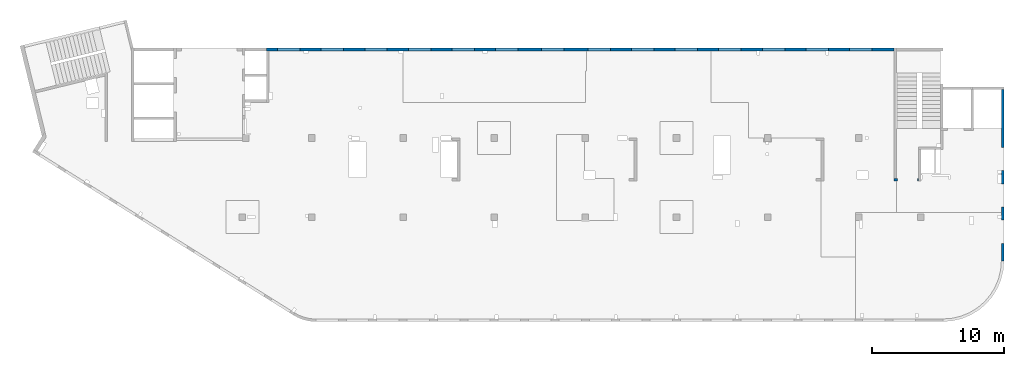
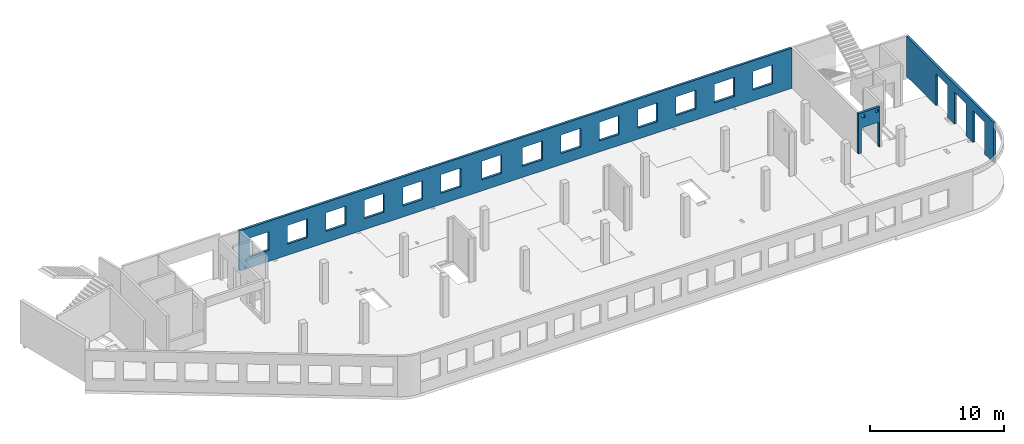
# One storey, part 6 of 6: 3 walls, 20 openings.
"""IFC4 building model written with IfcOpenShell, lengths in millimetres."""

from ifc_helpers import new_model, entity, si_unit, converted_unit, derived_unit, direction, frame, origin, place, context, subcontext, project, spatial, indexed_curve, outline, extrude, polygons, material, type_object, element, save


model = new_model("IFC4")

# Units and contexts
model_context = context("Model", 3, precision=0.01, world=origin(), true_north=direction((6.12303176911189e-17, 1.0)))
plan_context = context("Plan", 3, precision=0.01, world=origin(), true_north=direction((6.12303176911189e-17, 1.0)))
body_context = subcontext(model_context, "Body", "Model", "MODEL_VIEW")
ifc_project = project(units=[si_unit("LENGTHUNIT", "METRE", prefix="MILLI"), si_unit("AREAUNIT", "SQUARE_METRE"), si_unit("VOLUMEUNIT", "CUBIC_METRE"), converted_unit("PLANEANGLEUNIT", "DEGREE", entity("IfcRatioMeasure", 0.0174532925199433), si_unit("PLANEANGLEUNIT", "RADIAN"), dimensions=[0, 0, 0, 0, 0, 0, 0]), si_unit("MASSUNIT", "GRAM", prefix="KILO"), derived_unit("MASSDENSITYUNIT", [(si_unit("MASSUNIT", "GRAM", prefix="KILO"), 1), (si_unit("LENGTHUNIT", "METRE"), -3)]), derived_unit("MOMENTOFINERTIAUNIT", [(si_unit("LENGTHUNIT", "METRE"), 4)]), si_unit("TIMEUNIT", "SECOND"), si_unit("FREQUENCYUNIT", "HERTZ"), si_unit("THERMODYNAMICTEMPERATUREUNIT", "DEGREE_CELSIUS"), derived_unit("THERMALTRANSMITTANCEUNIT", [(si_unit("MASSUNIT", "GRAM", prefix="KILO"), 1), (si_unit("THERMODYNAMICTEMPERATUREUNIT", "KELVIN"), -1), (si_unit("TIMEUNIT", "SECOND"), -3)]), derived_unit("VOLUMETRICFLOWRATEUNIT", [(si_unit("LENGTHUNIT", "METRE"), 3), (si_unit("TIMEUNIT", "SECOND"), -1)]), derived_unit("MASSFLOWRATEUNIT", [(si_unit("MASSUNIT", "GRAM", prefix="KILO"), 1), (si_unit("TIMEUNIT", "SECOND"), -1)]), derived_unit("ROTATIONALFREQUENCYUNIT", [(si_unit("TIMEUNIT", "SECOND"), -1)]), si_unit("ELECTRICCURRENTUNIT", "AMPERE"), si_unit("ELECTRICVOLTAGEUNIT", "VOLT"), si_unit("POWERUNIT", "WATT"), si_unit("FORCEUNIT", "NEWTON", prefix="KILO"), si_unit("ILLUMINANCEUNIT", "LUX"), si_unit("LUMINOUSFLUXUNIT", "LUMEN"), si_unit("LUMINOUSINTENSITYUNIT", "CANDELA"), derived_unit("USERDEFINED", [(si_unit("MASSUNIT", "GRAM", prefix="KILO"), -1), (si_unit("LENGTHUNIT", "METRE"), -2), (si_unit("TIMEUNIT", "SECOND"), 3), (si_unit("LUMINOUSFLUXUNIT", "LUMEN"), 1)]), derived_unit("LINEARVELOCITYUNIT", [(si_unit("LENGTHUNIT", "METRE"), 1), (si_unit("TIMEUNIT", "SECOND"), -1)]), si_unit("PRESSUREUNIT", "PASCAL"), derived_unit("USERDEFINED", [(si_unit("LENGTHUNIT", "METRE"), -2), (si_unit("MASSUNIT", "GRAM", prefix="KILO"), 1), (si_unit("TIMEUNIT", "SECOND"), -2)]), derived_unit("LINEARFORCEUNIT", [(si_unit("MASSUNIT", "GRAM", prefix="KILO"), 1), (si_unit("LENGTHUNIT", "METRE"), 1), (si_unit("TIMEUNIT", "SECOND"), -2), (si_unit("LENGTHUNIT", "METRE"), -1)]), derived_unit("PLANARFORCEUNIT", [(si_unit("MASSUNIT", "GRAM", prefix="KILO"), 1), (si_unit("LENGTHUNIT", "METRE"), 1), (si_unit("TIMEUNIT", "SECOND"), -2), (si_unit("LENGTHUNIT", "METRE"), -2)])], contexts=[model_context, plan_context])

# Site, building, storey
site_placement = place(None, origin())
site = spatial("IfcSite", under=ifc_project, at=site_placement, CompositionType="ELEMENT")
building_placement = place(site_placement, origin())
building = spatial("IfcBuilding", under=site, at=building_placement, CompositionType="ELEMENT")
storey_placement = place(building_placement, frame((0.0, 0.0, 8100.0)))
storey = spatial("IfcBuildingStorey", under=building, at=storey_placement, Name="03", CompositionType="ELEMENT", Elevation=8100.0)

# Wall, openings
ifc_material = material()
wall_type = type_object("IfcWallType", Name=":ADSK_ 25_200", PredefinedType="STANDARD")
wall_1_placement = place(storey_placement, frame((73470.0, 17370.0, -150.0), z_axis=(0.0, 0.0, 1.0), x_axis=(0.0, -1.0, 0.0)))
wall_1 = element("IfcWall", 1, at=wall_1_placement, inside=storey, type_object=wall_type, material=ifc_material, Name=":ADSK_ 25_200", ObjectType=":ADSK_ 25_200", PredefinedType="NOTDEFINED", context=body_context, shape_type="Tessellation", body=[
    polygons([(12970.0, -99.9999999999918, 0.0), (12970.0, -99.9999999999918, 3200.0), (12970.0, -99.9999999999918, 3650.0), (9560.00000000002, -99.9999999999877, 3650.0), (9360.00000000002, -99.999999999988, 3650.0), (7085.00000000004, -99.999999999991, 3650.0), (6485.00000000003, -99.9999999999918, 3650.0), (6320.00000000002, -99.999999999992, 3650.0), (6120.00000000002, -99.9999999999923, 3650.0), (0.0, -99.9999999999831, 3650.0), (0.0, -99.9999999999831, 0.0), (4394.99999999951, -99.9999999999946, 0.0), (4394.99999999951, -100.000000000315, 2900.0), (6144.99999999951, -100.000000000313, 2900.0), (6144.99999999951, -99.9999999999923, 0.0), (6319.99895780055, -99.999999999992, 0.0), (6485.00000000002, -99.9999999999918, 0.0), (7084.99895780057, -99.999999999991, 0.0), (7144.99999999951, -99.9999999999909, 0.0), (7144.99999999951, -100.000000000311, 2900.0), (8894.99999999951, -100.000000000309, 2900.0), (8894.99999999951, -99.9999999999886, 0.0), (9895.00000000005, -99.9999999999959, 0.0), (9895.00000000005, -99.9999999999959, 2900.0), (11645.0, -99.9999999999936, 2900.0), (11645.0, -99.9999999999936, 0.0), (12970.0, 100.000000000006, 3650.0), (12970.0, 100.000000000006, 3200.0), (12970.0, 100.000000000006, 0.0), (11645.0, 100.000000000004, 0.0), (11645.0, 100.000000000316, 2900.0), (9895.00000000005, 100.000000000314, 2900.0), (9895.00000000004, 100.000000000002, 0.0), (8894.99999999951, 100.000000000001, 0.0), (8894.99999999951, 100.000000000001, 2900.0), (7144.99999999951, 99.9999999999983, 2900.0), (7144.99999999951, 99.9999999999983, 0.0), (6144.99999999951, 99.9999999999969, 0.0), (6144.99999999951, 99.9999999999969, 2900.0), (4394.99999999951, 99.9999999999946, 2900.0), (4394.99999999951, 99.9999999999946, 0.0), (0.0, 100.000000000006, 0.0), (0.0, 100.000000000006, 3650.0)], [[[1, 2, 3, 4, 5, 6, 7, 8, 9, 10, 11, 12, 13, 14, 15, 16, 17, 18, 19, 20, 21, 22, 23, 24, 25, 26]], [[27, 28, 29, 30, 31, 32, 33, 34, 35, 36, 37, 38, 39, 40, 41, 42, 43]], [[11, 42, 41, 12]], [[3, 2, 1, 29, 28, 27]], [[10, 9, 8, 7, 6, 5, 4, 3, 27, 43]], [[11, 10, 43, 42]], [[24, 32, 31, 25]], [[32, 24, 23, 33]], [[25, 31, 30, 26]], [[35, 21, 20, 36]], [[21, 35, 34, 22]], [[36, 20, 19, 37]], [[39, 14, 13, 40]], [[14, 39, 38, 15]], [[40, 13, 12, 41]], [[37, 19, 18, 17, 16, 15, 38]], [[33, 23, 22, 34]], [[29, 1, 26, 30]]], closed=True),
])
placement_1 = place(wall_1_placement, frame((17370.0, -73470.0, 150.0), z_axis=(0.0, 0.0, 1.0), x_axis=(0.0, 1.0, 0.0)))
element("IfcOpeningElement", 2, at=placement_1, cuts=wall_1, Name=":ADSK_ 25_200", PredefinedType="OPENING", context=body_context, shape_type="SweptSolid", body=[
    extrude(outline(indexed_curve([(-1449.99999999999, -874.999999999999), (1449.99999999999, -874.999999999999), (1449.99999999999, 875.0), (-1449.99999999999, 875.0), (-1449.99999999999, -874.999999999999)], self_intersect=False)), frame((73370.0, 6600.0, 1300.0), z_axis=(1.0, 0.0, 0.0), x_axis=(0.0, 0.0, -1.0)), (0.0, 0.0, 1.0), 200.000000000968),
])
element("IfcOpeningElement", 3, at=placement_1, cuts=wall_1, Name=":ADSK_ 25_200", PredefinedType="OPENING", context=body_context, shape_type="SweptSolid", body=[
    extrude(outline(indexed_curve([(-874.999999999999, -1449.99999999999), (874.999999999999, -1449.99999999999), (874.999999999999, 1450.0), (-874.999999999999, 1450.0), (-874.999999999999, -1449.99999999999)], self_intersect=False)), frame((73370.0, 9350.0, 1300.0), z_axis=(1.0, 0.0, 0.0), x_axis=(0.0, -1.0, 0.0)), (0.0, 0.0, 1.0), 200.000000000968),
])
element("IfcOpeningElement", 4, at=placement_1, cuts=wall_1, Name=":ADSK_ 25_200", PredefinedType="OPENING", context=body_context, shape_type="SweptSolid", body=[
    extrude(outline(indexed_curve([(-875.0, -1449.99999999999), (874.999999999998, -1449.99999999999), (874.999999999998, 1450.0), (-875.0, 1450.0), (-875.0, -1449.99999999999)], self_intersect=False)), frame((73370.0, 12100.0, 1300.0), z_axis=(1.0, 0.0, 0.0), x_axis=(0.0, -1.0, 0.0)), (0.0, 0.0, 1.0), 200.000000000968),
])

wall_2_placement = place(storey_placement, frame((67080.0, 10525.0, -150.0), z_axis=(0.0, 0.0, 1.0), x_axis=(-1.0, 0.0, 0.0)))
wall_2 = element("IfcWall", 5, at=wall_2_placement, inside=storey, type_object=wall_type, material=ifc_material, Name=":ADSK_ 25_200", ObjectType=":ADSK_ 25_200", PredefinedType="NOTDEFINED", context=body_context, shape_type="Tessellation", body=[
    polygons([(1849.99999999999, -100.000000000001, 3650.0), (1650.0, -100.000000000003, 3650.0), (-9.772240076716e-13, -100.000000000001, 3650.0), (-9.772240076716e-13, -100.000000000001, 0.0), (74.9999999999906, -100.000000000001, 0.0), (74.9999999999906, -100.000000000001, 2279.99999999805), (1575.0, -100.000000000001, 2279.99999999804), (1575.0, -100.000000000003, 0.0), (1650.0, -100.000000000003, 0.0), (1849.99999999999, -100.000000000001, 0.0), (125.000000000014, -100.000000000322, 3490.0), (375.000000000009, -100.000000000324, 3490.0), (375.000000000009, -100.000000000324, 3240.00000000001), (125.000000000014, -100.000000000322, 3240.00000000001), (1275.0, -100.000000000322, 3400.0), (1524.99999999999, -100.000000000322, 3400.0), (1524.99999999999, -100.000000000322, 3150.00000000001), (1275.0, -100.000000000322, 3150.00000000001), (-1.61109744921212e-12, 99.9999999999989, 3650.0), (1849.99999999999, 99.9999999999989, 3650.0), (1849.99999999999, 99.9999999999989, 0.0), (1575.0, 99.9999999999968, 0.0), (1575.0, 99.9999999999968, 2279.99999999804), (74.99999999999, 99.9999999999989, 2279.99999999805), (74.99999999999, 99.9999999999989, 0.0), (-1.61109744921212e-12, 99.9999999999989, 0.0), (375.000000000008, 99.9999999999968, 3490.0), (125.000000000013, 99.9999999999968, 3490.0), (125.000000000013, 99.9999999999968, 3240.00000000001), (375.000000000008, 99.9999999999968, 3240.00000000001), (1524.99999999999, 99.9999999999968, 3400.0), (1275.0, 99.9999999999989, 3400.0), (1275.0, 99.9999999999989, 3150.00000000001), (1524.99999999999, 99.9999999999968, 3150.00000000001)], [[[1, 2, 3, 4, 5, 6, 7, 8, 9, 10], [11, 12, 13, 14], [15, 16, 17, 18]], [[19, 20, 21, 22, 23, 24, 25, 26], [27, 28, 29, 30], [31, 32, 33, 34]], [[4, 26, 25, 5]], [[3, 2, 1, 20, 19]], [[4, 3, 19, 26]], [[1, 10, 21, 20]], [[12, 11, 28, 27]], [[12, 27, 30, 13]], [[13, 30, 29, 14]], [[28, 11, 14, 29]], [[16, 15, 32, 31]], [[16, 31, 34, 17]], [[17, 34, 33, 18]], [[32, 15, 18, 33]], [[6, 24, 23, 7]], [[7, 23, 22, 8]], [[24, 6, 5, 25]], [[21, 10, 9, 8, 22]]], closed=True),
])
placement_2 = place(wall_2_placement, frame((67080.0, 10525.0, 150.0), z_axis=(0.0, 0.0, 1.0), x_axis=(-1.0, 0.0, 0.0)))
element("IfcOpeningElement", 6, at=placement_2, cuts=wall_2, Name=":ADSK_ 25_200", PredefinedType="OPENING", context=body_context, shape_type="SweptSolid", body=[
    extrude(outline(indexed_curve([(-750.000000000003, -1139.99999999902), (749.999999999994, -1139.99999999902), (749.999999999994, 1139.99999999902), (-750.000000000003, 1139.99999999902), (-750.000000000003, -1139.99999999902)], self_intersect=False)), frame((66255.0, 10725.0, 990.0), z_axis=(0.0, -1.0, 0.0), x_axis=(-1.0, 0.0, 0.0)), (0.0, 0.0, 1.0), 400.000000001943),
])
element("IfcOpeningElement", 7, at=placement_2, cuts=wall_2, Name=":ADSK_ 25_200", PredefinedType="OPENING", context=body_context, shape_type="SweptSolid", body=[
    extrude(outline(indexed_curve([(-125.000000000006, -124.999999999993), (124.999999999998, -124.999999999993), (124.999999999998, 124.999999999993), (-125.000000000006, 124.999999999993), (-125.000000000006, -124.999999999993)], self_intersect=False)), frame((65680.0, 10625.0, 3125.0), z_axis=(0.0, -1.0, 0.0), x_axis=(-1.0, 0.0, 0.0)), (0.0, 0.0, 1.0), 200.000000000962),
])
element("IfcOpeningElement", 8, at=placement_2, cuts=wall_2, Name=":ADSK_ 25_200", PredefinedType="OPENING", context=body_context, shape_type="SweptSolid", body=[
    extrude(outline(indexed_curve([(-125.000000000006, -124.999999999993), (124.999999999998, -124.999999999993), (124.999999999998, 124.999999999993), (-125.000000000006, 124.999999999993), (-125.000000000006, -124.999999999993)], self_intersect=False)), frame((66830.0, 10625.0, 3215.0), z_axis=(0.0, -1.0, 0.0), x_axis=(-1.0, 0.0, 0.0)), (0.0, 0.0, 1.0), 200.000000000962),
])

wall_3_placement = place(storey_placement, frame((65230.0, 20400.0, -150.0), z_axis=(0.0, 0.0, 1.0), x_axis=(-1.0, 0.0, 0.0)))
wall_3 = element("IfcWall", 9, at=wall_3_placement, inside=storey, type_object=wall_type, material=ifc_material, Name=":ADSK_ 25_200", ObjectType=":ADSK_ 25_200", PredefinedType="NOTDEFINED", context=body_context, shape_type="Tessellation", body=[
    polygons([(8.66293703438714e-12, -99.9999999999989, 0.0), (47505.0, -99.9999999999989, 0.0), (47505.0, -99.9999999999989, 3650.0), (8.66293703438714e-12, -99.9999999999989, 3650.0), (28460.0, -100.000000000319, 2700.0), (30160.0, -100.000000000319, 2700.0), (30160.0, -100.000000000319, 1000.00000000001), (28460.0, -100.000000000319, 1000.00000000001), (1660.00000000009, -100.000000000319, 2700.0), (3360.00000000009, -100.000000000319, 2700.0), (3360.00000000009, -100.000000000319, 1000.00000000001), (1660.00000000009, -100.000000000319, 1000.00000000001), (4960.00000000009, -100.000000000319, 2700.0), (6660.00000000009, -100.000000000319, 2700.0), (6660.00000000009, -100.000000000319, 1000.00000000001), (4960.00000000009, -100.000000000319, 1000.00000000001), (8260.00000000008, -100.000000000319, 2700.0), (9960.00000000008, -100.000000000319, 2700.0), (9960.00000000008, -100.000000000319, 1000.00000000001), (8260.00000000008, -100.000000000319, 1000.00000000001), (11560.0000000001, -100.000000000319, 2700.0), (13260.0000000001, -100.000000000319, 2700.0), (13260.0000000001, -100.000000000319, 1000.00000000001), (11560.0000000001, -100.000000000319, 1000.00000000001), (14860.0000000001, -100.000000000319, 2700.0), (16560.0000000001, -100.000000000319, 2700.0), (16560.0000000001, -100.000000000319, 1000.00000000001), (14860.0000000001, -100.000000000319, 1000.00000000001), (18160.0000000001, -100.000000000319, 2700.0), (19860.0000000001, -100.000000000319, 2700.0), (19860.0000000001, -100.000000000319, 1000.00000000001), (18160.0000000001, -100.000000000319, 1000.00000000001), (21460.0000000001, -100.000000000319, 2700.0), (23160.0000000001, -100.000000000319, 2700.0), (23160.0000000001, -100.000000000319, 1000.00000000001), (21460.0000000001, -100.000000000319, 1000.00000000001), (24960.0000000001, -100.000000000319, 2700.0), (26660.0000000001, -100.000000000319, 2700.0), (26660.0000000001, -100.000000000319, 1000.00000000001), (24960.0000000001, -100.000000000319, 1000.00000000001), (31760.0000000001, -100.000000000319, 2700.0), (33460.0000000001, -100.000000000319, 2700.0), (33460.0000000001, -100.000000000319, 1000.00000000001), (31760.0000000001, -100.000000000319, 1000.00000000001), (35060.0000000001, -100.000000000319, 2700.0), (36760.0000000001, -100.000000000319, 2700.0), (36760.0000000001, -100.000000000319, 1000.00000000001), (35060.0000000001, -100.000000000319, 1000.00000000001), (38360.0000000001, -100.000000000319, 2700.0), (40060.0000000001, -100.000000000319, 2700.0), (40060.0000000001, -100.000000000319, 1000.00000000001), (38360.0000000001, -100.000000000319, 1000.00000000001), (41660.0, -100.000000000319, 2700.0), (43360.0, -100.000000000319, 2700.0), (43360.0, -100.000000000319, 1000.00000000001), (41660.0, -100.000000000319, 1000.00000000001), (44960.0, -100.000000000319, 2700.0), (46660.0, -100.000000000319, 2700.0), (46660.0, -100.000000000319, 1000.00000000001), (44960.0, -100.000000000319, 1000.00000000001), (8.66293703438714e-12, 99.9999999999989, 0.0), (8.66293703438714e-12, 99.9999999999989, 3650.0), (47305.0, 99.9999999999989, 3650.0), (47505.0, 99.9999999999989, 3650.0), (47505.0, 99.9999999999989, 0.0), (47305.0, 99.9999999999989, 0.0), (44660.0000000001, 99.9999999999989, 0.0), (44360.0000000001, 99.9999999999989, 0.0), (37460.0000000001, 99.9999999999989, 0.0), (37160.0000000001, 99.9999999999989, 0.0), (10360.0000000001, 99.9999999999989, 0.0), (10160.0000000001, 99.9999999999989, 0.0), (5150.00000000013, 99.9999999999989, 0.0), (4950.0000000001, 99.9999999999989, 0.0), (30160.0, 99.9999999999989, 2700.0), (28460.0, 99.9999999999989, 2700.0), (28460.0, 99.9999999999989, 1000.00000000001), (30160.0, 99.9999999999989, 1000.00000000001), (3360.00000000009, 99.9999999999989, 2700.0), (1660.00000000009, 99.9999999999989, 2700.0), (1660.00000000009, 99.9999999999989, 1000.00000000001), (3360.00000000009, 99.9999999999989, 1000.00000000001), (6660.00000000009, 99.9999999999989, 2700.0), (4960.00000000009, 99.9999999999989, 2700.0), (4960.00000000009, 99.9999999999989, 1000.00000000001), (6660.00000000009, 99.9999999999989, 1000.00000000001), (9960.00000000008, 99.9999999999989, 2700.0), (8260.00000000008, 99.9999999999989, 2700.0), (8260.00000000008, 99.9999999999989, 1000.00000000001), (9960.00000000008, 99.9999999999989, 1000.00000000001), (13260.0000000001, 99.9999999999989, 2700.0), (11560.0000000001, 99.9999999999989, 2700.0), (11560.0000000001, 99.9999999999989, 1000.00000000001), (13260.0000000001, 99.9999999999989, 1000.00000000001), (16560.0000000001, 99.9999999999989, 2700.0), (14860.0000000001, 99.9999999999989, 2700.0), (14860.0000000001, 99.9999999999989, 1000.00000000001), (16560.0000000001, 99.9999999999989, 1000.00000000001), (19860.0000000001, 99.9999999999989, 2700.0), (18160.0000000001, 99.9999999999989, 2700.0), (18160.0000000001, 99.9999999999989, 1000.00000000001), (19860.0000000001, 99.9999999999989, 1000.00000000001), (23160.0000000001, 99.9999999999989, 2700.0), (21460.0000000001, 99.9999999999989, 2700.0), (21460.0000000001, 99.9999999999989, 1000.00000000001), (23160.0000000001, 99.9999999999989, 1000.00000000001), (26660.0000000001, 99.9999999999989, 2700.0), (24960.0000000001, 99.9999999999989, 2700.0), (24960.0000000001, 99.9999999999989, 1000.00000000001), (26660.0000000001, 99.9999999999989, 1000.00000000001), (33460.0000000001, 99.9999999999989, 2700.0), (31760.0000000001, 99.9999999999989, 2700.0), (31760.0000000001, 99.9999999999989, 1000.00000000001), (33460.0000000001, 99.9999999999989, 1000.00000000001), (36760.0000000001, 99.9999999999989, 2700.0), (35060.0000000001, 99.9999999999989, 2700.0), (35060.0000000001, 99.9999999999989, 1000.00000000001), (36760.0000000001, 99.9999999999989, 1000.00000000001), (40060.0000000001, 99.9999999999989, 2700.0), (38360.0000000001, 99.9999999999989, 2700.0), (38360.0000000001, 99.9999999999989, 1000.00000000001), (40060.0000000001, 99.9999999999989, 1000.00000000001), (43360.0, 99.9999999999989, 2700.0), (41660.0, 99.9999999999989, 2700.0), (41660.0, 99.9999999999989, 1000.00000000001), (43360.0, 99.9999999999989, 1000.00000000001), (46660.0, 99.9999999999989, 2700.0), (44960.0, 99.9999999999989, 2700.0), (44960.0, 99.9999999999989, 1000.00000000001), (46660.0, 99.9999999999989, 1000.00000000001)], [[[1, 2, 3, 4], [5, 6, 7, 8], [9, 10, 11, 12], [13, 14, 15, 16], [17, 18, 19, 20], [21, 22, 23, 24], [25, 26, 27, 28], [29, 30, 31, 32], [33, 34, 35, 36], [37, 38, 39, 40], [41, 42, 43, 44], [45, 46, 47, 48], [49, 50, 51, 52], [53, 54, 55, 56], [57, 58, 59, 60]], [[61, 62, 63, 64, 65, 66, 67, 68, 69, 70, 71, 72, 73, 74], [75, 76, 77, 78], [79, 80, 81, 82], [83, 84, 85, 86], [87, 88, 89, 90], [91, 92, 93, 94], [95, 96, 97, 98], [99, 100, 101, 102], [103, 104, 105, 106], [107, 108, 109, 110], [111, 112, 113, 114], [115, 116, 117, 118], [119, 120, 121, 122], [123, 124, 125, 126], [127, 128, 129, 130]], [[2, 1, 61, 74, 73, 72, 71, 70, 69, 68, 67, 66, 65]], [[4, 3, 64, 63, 62]], [[1, 4, 62, 61]], [[3, 2, 65, 64]], [[6, 5, 76, 75]], [[6, 75, 78, 7]], [[7, 78, 77, 8]], [[76, 5, 8, 77]], [[10, 9, 80, 79]], [[10, 79, 82, 11]], [[11, 82, 81, 12]], [[80, 9, 12, 81]], [[14, 13, 84, 83]], [[14, 83, 86, 15]], [[15, 86, 85, 16]], [[84, 13, 16, 85]], [[18, 17, 88, 87]], [[18, 87, 90, 19]], [[19, 90, 89, 20]], [[88, 17, 20, 89]], [[22, 21, 92, 91]], [[22, 91, 94, 23]], [[23, 94, 93, 24]], [[92, 21, 24, 93]], [[26, 25, 96, 95]], [[26, 95, 98, 27]], [[27, 98, 97, 28]], [[96, 25, 28, 97]], [[30, 29, 100, 99]], [[30, 99, 102, 31]], [[31, 102, 101, 32]], [[100, 29, 32, 101]], [[34, 33, 104, 103]], [[34, 103, 106, 35]], [[35, 106, 105, 36]], [[104, 33, 36, 105]], [[38, 37, 108, 107]], [[38, 107, 110, 39]], [[39, 110, 109, 40]], [[108, 37, 40, 109]], [[42, 41, 112, 111]], [[42, 111, 114, 43]], [[43, 114, 113, 44]], [[112, 41, 44, 113]], [[46, 45, 116, 115]], [[46, 115, 118, 47]], [[47, 118, 117, 48]], [[116, 45, 48, 117]], [[50, 49, 120, 119]], [[50, 119, 122, 51]], [[51, 122, 121, 52]], [[120, 49, 52, 121]], [[54, 53, 124, 123]], [[54, 123, 126, 55]], [[55, 126, 125, 56]], [[124, 53, 56, 125]], [[58, 57, 128, 127]], [[58, 127, 130, 59]], [[59, 130, 129, 60]], [[128, 57, 60, 129]]], closed=True),
])
placement_3 = place(wall_3_placement, frame((65230.0, 20400.0, 150.0), z_axis=(0.0, 0.0, 1.0), x_axis=(-1.0, 0.0, 0.0)))
element("IfcOpeningElement", 10, at=placement_3, cuts=wall_3, Name=":ADSK_ 25_200", PredefinedType="OPENING", context=body_context, shape_type="SweptSolid", body=[
    extrude(outline(indexed_curve([(-850.000000000002, -849.999999999995), (850.0, -849.999999999995), (850.0, 849.999999999993), (-850.000000000002, 849.999999999993), (-850.000000000002, -849.999999999995)], self_intersect=False)), frame((19420.0, 20500.0, 1700.0), z_axis=(0.0, -1.0, 0.0), x_axis=(-1.0, 0.0, 0.0)), (0.0, 0.0, 1.0), 200.000000000959),
])
element("IfcOpeningElement", 11, at=placement_3, cuts=wall_3, Name=":ADSK_ 25_200", PredefinedType="OPENING", context=body_context, shape_type="SweptSolid", body=[
    extrude(outline(indexed_curve([(-850.000000000002, -849.999999999995), (849.999999999997, -849.999999999995), (849.999999999997, 849.999999999993), (-850.000000000002, 849.999999999993), (-850.000000000002, -849.999999999995)], self_intersect=False)), frame((22720.0, 20500.0, 1700.0), z_axis=(0.0, -1.0, 0.0), x_axis=(-1.0, 0.0, 0.0)), (0.0, 0.0, 1.0), 200.000000000959),
])
element("IfcOpeningElement", 12, at=placement_3, cuts=wall_3, Name=":ADSK_ 25_200", PredefinedType="OPENING", context=body_context, shape_type="SweptSolid", body=[
    extrude(outline(indexed_curve([(-850.000000000002, -849.999999999995), (849.999999999997, -849.999999999995), (849.999999999997, 849.999999999993), (-850.000000000002, 849.999999999993), (-850.000000000002, -849.999999999995)], self_intersect=False)), frame((26020.0, 20500.0, 1700.0), z_axis=(0.0, -1.0, 0.0), x_axis=(-1.0, 0.0, 0.0)), (0.0, 0.0, 1.0), 200.000000000959),
])
element("IfcOpeningElement", 13, at=placement_3, cuts=wall_3, Name=":ADSK_ 25_200", PredefinedType="OPENING", context=body_context, shape_type="SweptSolid", body=[
    extrude(outline(indexed_curve([(-850.000000000002, -849.999999999995), (849.999999999997, -849.999999999995), (849.999999999997, 849.999999999993), (-850.000000000002, 849.999999999993), (-850.000000000002, -849.999999999995)], self_intersect=False)), frame((29320.0, 20500.0, 1700.0), z_axis=(0.0, -1.0, 0.0), x_axis=(-1.0, 0.0, 0.0)), (0.0, 0.0, 1.0), 200.000000000959),
])
element("IfcOpeningElement", 14, at=placement_3, cuts=wall_3, Name=":ADSK_ 25_200", PredefinedType="OPENING", context=body_context, shape_type="SweptSolid", body=[
    extrude(outline(indexed_curve([(-849.999999999997, -849.999999999995), (850.000000000002, -849.999999999995), (850.000000000002, 849.999999999993), (-849.999999999997, 849.999999999993), (-849.999999999997, -849.999999999995)], self_intersect=False)), frame((32620.0, 20500.0, 1700.0), z_axis=(0.0, -1.0, 0.0), x_axis=(-1.0, 0.0, 0.0)), (0.0, 0.0, 1.0), 200.000000000959),
])
element("IfcOpeningElement", 15, at=placement_3, cuts=wall_3, Name=":ADSK_ 25_200", PredefinedType="OPENING", context=body_context, shape_type="SweptSolid", body=[
    extrude(outline(indexed_curve([(-849.999999999997, -849.999999999995), (850.000000000006, -849.999999999995), (850.000000000006, 849.999999999993), (-849.999999999997, 849.999999999993), (-849.999999999997, -849.999999999995)], self_intersect=False)), frame((39420.0, 20500.0, 1700.0), z_axis=(0.0, -1.0, 0.0), x_axis=(-1.0, 0.0, 0.0)), (0.0, 0.0, 1.0), 200.000000000959),
])
element("IfcOpeningElement", 16, at=placement_3, cuts=wall_3, Name=":ADSK_ 25_200", PredefinedType="OPENING", context=body_context, shape_type="SweptSolid", body=[
    extrude(outline(indexed_curve([(-850.000000000006, -849.999999999995), (849.999999999997, -849.999999999995), (849.999999999997, 849.999999999993), (-850.000000000006, 849.999999999993), (-850.000000000006, -849.999999999995)], self_intersect=False)), frame((42920.0, 20500.0, 1700.0), z_axis=(0.0, -1.0, 0.0), x_axis=(-1.0, 0.0, 0.0)), (0.0, 0.0, 1.0), 200.000000000959),
])
element("IfcOpeningElement", 17, at=placement_3, cuts=wall_3, Name=":ADSK_ 25_200", PredefinedType="OPENING", context=body_context, shape_type="SweptSolid", body=[
    extrude(outline(indexed_curve([(-849.999999999997, -849.999999999995), (850.000000000006, -849.999999999995), (850.000000000006, 849.999999999993), (-849.999999999997, 849.999999999993), (-849.999999999997, -849.999999999995)], self_intersect=False)), frame((46220.0, 20500.0, 1700.0), z_axis=(0.0, -1.0, 0.0), x_axis=(-1.0, 0.0, 0.0)), (0.0, 0.0, 1.0), 200.000000000959),
])
element("IfcOpeningElement", 18, at=placement_3, cuts=wall_3, Name=":ADSK_ 25_200", PredefinedType="OPENING", context=body_context, shape_type="SweptSolid", body=[
    extrude(outline(indexed_curve([(-849.999999999997, -849.999999999995), (850.000000000006, -849.999999999995), (850.000000000006, 849.999999999993), (-849.999999999997, 849.999999999993), (-849.999999999997, -849.999999999995)], self_intersect=False)), frame((49520.0, 20500.0, 1700.0), z_axis=(0.0, -1.0, 0.0), x_axis=(-1.0, 0.0, 0.0)), (0.0, 0.0, 1.0), 200.000000000959),
])
element("IfcOpeningElement", 19, at=placement_3, cuts=wall_3, Name=":ADSK_ 25_200", PredefinedType="OPENING", context=body_context, shape_type="SweptSolid", body=[
    extrude(outline(indexed_curve([(-849.999999999997, -849.999999999995), (850.000000000006, -849.999999999995), (850.000000000006, 849.999999999993), (-849.999999999997, 849.999999999993), (-849.999999999997, -849.999999999995)], self_intersect=False)), frame((52820.0, 20500.0, 1700.0), z_axis=(0.0, -1.0, 0.0), x_axis=(-1.0, 0.0, 0.0)), (0.0, 0.0, 1.0), 200.000000000959),
])
element("IfcOpeningElement", 20, at=placement_3, cuts=wall_3, Name=":ADSK_ 25_200", PredefinedType="OPENING", context=body_context, shape_type="SweptSolid", body=[
    extrude(outline(indexed_curve([(-849.999999999997, -849.999999999995), (850.000000000006, -849.999999999995), (850.000000000006, 849.999999999993), (-849.999999999997, 849.999999999993), (-849.999999999997, -849.999999999995)], self_intersect=False)), frame((56120.0, 20500.0, 1700.0), z_axis=(0.0, -1.0, 0.0), x_axis=(-1.0, 0.0, 0.0)), (0.0, 0.0, 1.0), 200.000000000959),
])
element("IfcOpeningElement", 21, at=placement_3, cuts=wall_3, Name=":ADSK_ 25_200", PredefinedType="OPENING", context=body_context, shape_type="SweptSolid", body=[
    extrude(outline(indexed_curve([(-849.999999999997, -849.999999999995), (850.000000000006, -849.999999999995), (850.000000000006, 849.999999999993), (-849.999999999997, 849.999999999993), (-849.999999999997, -849.999999999995)], self_intersect=False)), frame((59420.0, 20500.0, 1700.0), z_axis=(0.0, -1.0, 0.0), x_axis=(-1.0, 0.0, 0.0)), (0.0, 0.0, 1.0), 200.000000000959),
])
element("IfcOpeningElement", 22, at=placement_3, cuts=wall_3, Name=":ADSK_ 25_200", PredefinedType="OPENING", context=body_context, shape_type="SweptSolid", body=[
    extrude(outline(indexed_curve([(-849.999999999997, -849.999999999995), (850.000000000006, -849.999999999995), (850.000000000006, 849.999999999993), (-849.999999999997, 849.999999999993), (-849.999999999997, -849.999999999995)], self_intersect=False)), frame((62720.0, 20500.0, 1700.0), z_axis=(0.0, -1.0, 0.0), x_axis=(-1.0, 0.0, 0.0)), (0.0, 0.0, 1.0), 200.000000000959),
])
element("IfcOpeningElement", 23, at=placement_3, cuts=wall_3, Name=":ADSK_ 25_200", PredefinedType="OPENING", context=body_context, shape_type="SweptSolid", body=[
    extrude(outline(indexed_curve([(-849.999999999997, -849.999999999995), (850.000000000002, -849.999999999995), (850.000000000002, 849.999999999993), (-849.999999999997, 849.999999999993), (-849.999999999997, -849.999999999995)], self_intersect=False)), frame((35920.0, 20500.0, 1700.0), z_axis=(0.0, -1.0, 0.0), x_axis=(-1.0, 0.0, 0.0)), (0.0, 0.0, 1.0), 200.000000000959),
])

save(model, "model.ifc")
